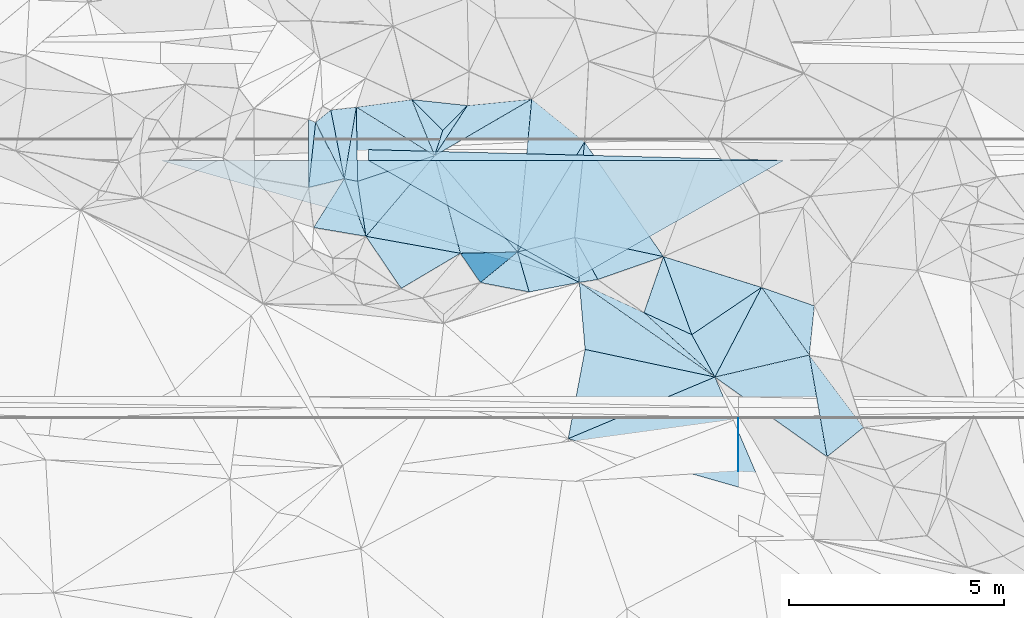
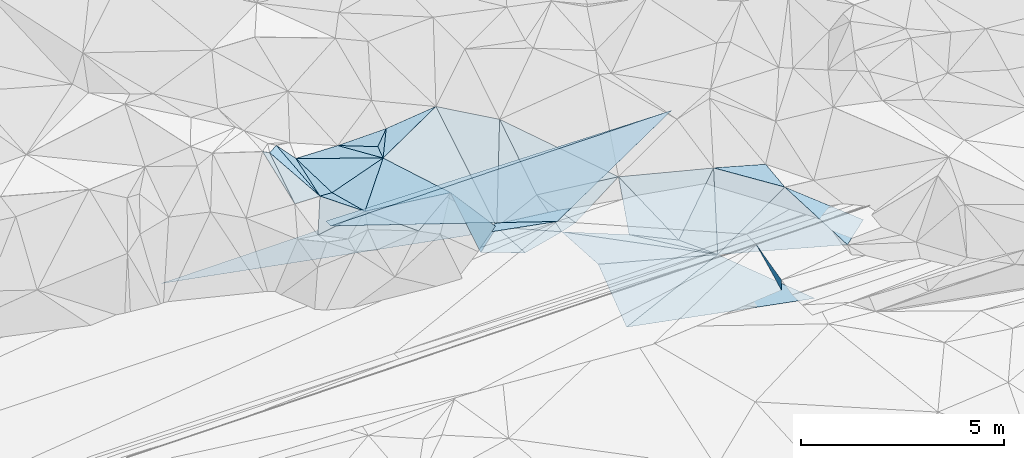
# One storey, part 49 of 275: 49 plates.
"""IFC2X3 building model written with IfcOpenShell, lengths in millimetres."""

from ifc_helpers import new_model, si_unit, frame, origin_with_axes, place, context, subcontext, project, spatial, polyline, outline, extrude, material, type_object, element, save


model = new_model("IFC2X3")

# Units and contexts
model_context = context("Model", 3, precision=1e-05, world=origin_with_axes())
body_context = subcontext(model_context, "Body", "Model", "MODEL_VIEW")
ifc_project = project(units=[si_unit("LENGTHUNIT", "METRE", prefix="MILLI"), si_unit("AREAUNIT", "SQUARE_METRE"), si_unit("VOLUMEUNIT", "CUBIC_METRE"), si_unit("MASSUNIT", "GRAM", prefix="KILO"), si_unit("TIMEUNIT", "SECOND"), si_unit("PLANEANGLEUNIT", "RADIAN"), si_unit("SOLIDANGLEUNIT", "STERADIAN"), si_unit("THERMODYNAMICTEMPERATUREUNIT", "DEGREE_CELSIUS"), si_unit("LUMINOUSINTENSITYUNIT", "LUMEN")], contexts=[model_context])

# Site, building, storey
site_placement = place(None, origin_with_axes())
site = spatial("IfcSite", under=ifc_project, at=site_placement, CompositionType="ELEMENT")
building_placement = place(site_placement, origin_with_axes())
building = spatial("IfcBuilding", under=site, at=building_placement, Name="Undefined", CompositionType="ELEMENT")
storey_placement = place(building_placement, origin_with_axes())
storey = spatial("IfcBuildingStorey", under=building, at=storey_placement, Name="Undefined", CompositionType="ELEMENT", Elevation=0.0)

# Plates
ifc_material = material()
plate_type_1 = type_object("IfcPlateType", PredefinedType="NOTDEFINED")
for number, where, z_axis, x_axis, name in (
    (1, (-129444.521961676, 66044.2965018914, 48899.9311651703), (0.00832149793297365, -0.0249918019511436, -0.9996530210565), (0.999965340787191, -5.73519775278889e-05, 0.0083254990906575), "00_PR"),
    (2, (-129444.521961676, 66044.2965018914, 48899.9311651703), (0.00832149793297365, -0.0249918019511436, -0.9996530210565), (0.999965340787191, -5.73519775278889e-05, 0.0083254990906575), "00_PR"),
    (3, (-129444.521961676, 66044.2965018914, 48899.9311651703), (0.00832149793297365, -0.0249918019511436, -0.9996530210565), (0.999965340787191, -5.73519775278889e-05, 0.0083254990906575), "00_PR"),
):
    element("IfcPlate", number, at=place(storey_placement, frame(where, z_axis=z_axis, x_axis=x_axis)), inside=storey, type_object=plate_type_1, material=ifc_material, Name=name, context=body_context, shape_type="SweptSolid", body=[
        extrude(outline(polyline([(0.0, 0.0), (9668.6904296875, -3.96539689972997e-09), (4834.9169921875, 2750.859375), (0.0, 0.0)])), frame((-8.85201319254618e-08, 2.18876761149539e-07, -0.5000001331573), z_axis=(0.0, 0.0, 1.0), x_axis=(1.0, 0.0, 0.0)), (0.0, 0.0, 1.0), 1.0),
    ])
plate_type_2 = type_object("IfcPlateType", PredefinedType="NOTDEFINED")
for number, where, z_axis, x_axis, name in (
    (4, (-129444.521961676, 66044.2965018914, 48899.9311651703), (0.00832149793297365, -0.0249918019511436, -0.9996530210565), (5.72779774420735e-05, 0.999687644773175, -0.0249921909222736), "00_PR"),
    (5, (-129444.521961676, 66044.2965018914, 48899.9311651703), (0.00832149793297365, -0.0249918019511436, -0.9996530210565), (5.72779774420735e-05, 0.999687644773175, -0.0249921909222736), "00_PR"),
    (6, (-129444.521961676, 66044.2965018914, 48899.9311651703), (0.00832149793297365, -0.0249918019511436, -0.9996530210565), (5.72779774420735e-05, 0.999687644773175, -0.0249921909222736), "00_PR"),
):
    element("IfcPlate", number, at=place(storey_placement, frame(where, z_axis=z_axis, x_axis=x_axis)), inside=storey, type_object=plate_type_2, material=ifc_material, Name=name, context=body_context, shape_type="SweptSolid", body=[
        extrude(outline(polyline([(0.0, 0.0), (250.078109741211, 1.02591002359986e-09), (-2.01160454750061, 9668.6904296875), (0.0, 0.0)])), frame((-8.85201319254618e-08, 2.18876761149539e-07, -0.5000001331573), z_axis=(0.0, 0.0, 1.0), x_axis=(1.0, 0.0, 0.0)), (0.0, 0.0, 1.0), 1.0),
    ])
plate_type_3 = type_object("IfcPlateType", PredefinedType="NOTDEFINED")
plate_1_placement = place(storey_placement, frame((-130003.227472833, 65617.2037920158, 50249.5041689659), z_axis=(0.0757378480211885, -0.104639151422614, -0.991622118736101), x_axis=(0.977749258374854, -0.187314348891937, 0.0944442822335632)))
element("IfcPlate", 7, at=plate_1_placement, inside=storey, type_object=plate_type_3, material=ifc_material, Name="00", context=body_context, shape_type="SweptSolid", body=[
    extrude(outline(polyline([(0.0, 0.0), (317.647613525391, 1.92812876775861e-09), (761.850524902344, 1226.08471679688), (0.0, 0.0)])), frame((-8.85201319254618e-08, 2.18876761149539e-07, -0.5000001331573), z_axis=(0.0, 0.0, 1.0), x_axis=(1.0, 0.0, 0.0)), (0.0, 0.0, 1.0), 1.0),
])
plate_type_4 = type_object("IfcPlateType", PredefinedType="NOTDEFINED")
plate_2_placement = place(storey_placement, frame((-127137.605546516, 67321.4208764742, 50239.5053374167), z_axis=(0.0950803082554427, -0.110798728565862, -0.989284274983808), x_axis=(-0.702212597919709, -0.711862135152669, 0.0122379679169896)))
element("IfcPlate", 8, at=plate_2_placement, inside=storey, type_object=plate_type_4, material=ifc_material, Name="00", context=body_context, shape_type="SweptSolid", body=[
    extrude(outline(polyline([(0.0, 0.0), (817.129150390625, -2.46654963120818e-09), (810.643005371094, 1030.46496582031), (0.0, 0.0)])), frame((-8.85201319254618e-08, 2.18876761149539e-07, -0.5000001331573), z_axis=(0.0, 0.0, 1.0), x_axis=(1.0, 0.0, 0.0)), (0.0, 0.0, 1.0), 1.0),
])
plate_type_5 = type_object("IfcPlateType", PredefinedType="NOTDEFINED")
plate_3_placement = place(storey_placement, frame((-119179.632955102, 61513.3747925366, 49219.5090029932), z_axis=(-0.0880734483260921, 0.167321221963966, -0.981960628732352), x_axis=(0.587966270137878, -0.787011487859707, -0.186838387803474)))
element("IfcPlate", 9, at=plate_3_placement, inside=storey, type_object=plate_type_5, material=ifc_material, Name="00", context=body_context, shape_type="SweptSolid", body=[
    extrude(outline(polyline([(0.0, 0.0), (2140.8876953125, -8.41828295961022e-09), (2185.96240234375, 1086.49353027344), (0.0, 0.0)])), frame((-8.85201319254618e-08, 2.18876761149539e-07, -0.5000001331573), z_axis=(0.0, 0.0, 1.0), x_axis=(1.0, 0.0, 0.0)), (0.0, 0.0, 1.0), 1.0),
])
plate_type_6 = type_object("IfcPlateType", PredefinedType="NOTDEFINED")
plate_4_placement = place(storey_placement, frame((-125969.525330926, 63912.8597103929, 48939.5338192046), z_axis=(0.124923611641997, 0.339308757605483, -0.932343101152437), x_axis=(0.486195842697802, 0.798207706932544, 0.355637538987189)))
element("IfcPlate", 10, at=plate_4_placement, inside=storey, type_object=plate_type_6, material=ifc_material, Name="00", context=body_context, shape_type="SweptSolid", body=[
    extrude(outline(polyline([(0.0, 0.0), (3205.51098632813, 6.40284270048141e-09), (1020.02459716797, 961.743103027344), (0.0, 0.0)])), frame((-8.85201319254618e-08, 2.18876761149539e-07, -0.5000001331573), z_axis=(0.0, 0.0, 1.0), x_axis=(1.0, 0.0, 0.0)), (0.0, 0.0, 1.0), 1.0),
])
plate_type_7 = type_object("IfcPlateType", PredefinedType="NOTDEFINED")
plate_5_placement = place(storey_placement, frame((-120291.181343538, 63088.3693610962, 49229.5448180347), z_axis=(0.335384816319633, 0.242527733238209, -0.910328140613363), x_axis=(0.576684367356679, -0.816950570194428, -0.00518712882303245)))
element("IfcPlate", 11, at=plate_5_placement, inside=storey, type_object=plate_type_7, material=ifc_material, Name="00", context=body_context, shape_type="SweptSolid", body=[
    extrude(outline(polyline([(0.0, 0.0), (1927.84851074219, -3.20869730785489e-09), (1083.02600097656, 2296.41479492188), (0.0, 0.0)])), frame((-8.85201319254618e-08, 2.18876761149539e-07, -0.5000001331573), z_axis=(0.0, 0.0, 1.0), x_axis=(1.0, 0.0, 0.0)), (0.0, 0.0, 1.0), 1.0),
])
plate_type_8 = type_object("IfcPlateType", PredefinedType="NOTDEFINED")
plate_6_placement = place(storey_placement, frame((-129498.191015569, 64276.9670685408, 50429.5038337111), z_axis=(0.0631159994664881, -0.106634195896618, -0.992293060983915), x_axis=(-0.149120046090259, 0.982106199594028, -0.115024452065697)))
element("IfcPlate", 12, at=plate_6_placement, inside=storey, type_object=plate_type_8, material=ifc_material, Name="00", context=body_context, shape_type="SweptSolid", body=[
    extrude(outline(polyline([(0.0, 0.0), (1304.07055664063, -5.67524693906307e-10), (1615.94018554688, 1863.34033203125), (0.0, 0.0)])), frame((-8.85201319254618e-08, 2.18876761149539e-07, -0.5000001331573), z_axis=(0.0, 0.0, 1.0), x_axis=(1.0, 0.0, 0.0)), (0.0, 0.0, 1.0), 1.0),
])
plate_type_9 = type_object("IfcPlateType", PredefinedType="NOTDEFINED")
plate_7_placement = place(storey_placement, frame((-124532.389340275, 63204.5267932217, 48725.5550051156), z_axis=(0.0880257875821797, 0.447439800095917, -0.889971396175553), x_axis=(-0.889061882563132, 0.438226990051846, 0.132386079945739)))
element("IfcPlate", 13, at=plate_7_placement, inside=storey, type_object=plate_type_9, material=ifc_material, Name="00", context=body_context, shape_type="SweptSolid", body=[
    extrude(outline(polyline([(0.0, 0.0), (1616.48413085938, 8.94578988663852e-09), (622.802917480469, 988.937561035156), (0.0, 0.0)])), frame((-8.85201319254618e-08, 2.18876761149539e-07, -0.5000001331573), z_axis=(0.0, 0.0, 1.0), x_axis=(1.0, 0.0, 0.0)), (0.0, 0.0, 1.0), 1.0),
])
plate_type_10 = type_object("IfcPlateType", PredefinedType="NOTDEFINED")
plate_8_placement = place(storey_placement, frame((-124532.491158292, 63204.3223012122, 48725.5036896782), z_axis=(-0.115376126283496, 0.038431630829375, -0.992578137597041), x_axis=(0.814371086853017, -0.568495484194326, -0.116673121791162)))
element("IfcPlate", 14, at=plate_8_placement, inside=storey, type_object=plate_type_10, material=ifc_material, Name="00", context=body_context, shape_type="SweptSolid", body=[
    extrude(outline(polyline([(0.0, 0.0), (3874.0712890625, -4.55474946647882e-09), (1004.98455810547, 1202.99914550781), (0.0, 0.0)])), frame((-8.85201319254618e-08, 2.18876761149539e-07, -0.5000001331573), z_axis=(0.0, 0.0, 1.0), x_axis=(1.0, 0.0, 0.0)), (0.0, 0.0, 1.0), 1.0),
])
plate_type_11 = type_object("IfcPlateType", PredefinedType="NOTDEFINED")
plate_9_placement = place(storey_placement, frame((-125969.952740655, 63912.5752890697, 48939.6780395793), z_axis=(-0.729883354677773, -0.229538386835784, -0.643880747913111), x_axis=(-0.658758887831383, -0.0152879310351082, 0.752198781485204)))
element("IfcPlate", 15, at=plate_9_placement, inside=storey, type_object=plate_type_11, material=ifc_material, Name="00", context=body_context, shape_type="SweptSolid", body=[
    extrude(outline(polyline([(0.0, 0.0), (2020.74243164063, -2.76850187219679e-09), (2283.26977539063, 2338.22143554688), (0.0, 0.0)])), frame((-8.85201319254618e-08, 2.18876761149539e-07, -0.5000001331573), z_axis=(0.0, 0.0, 1.0), x_axis=(1.0, 0.0, 0.0)), (0.0, 0.0, 1.0), 1.0),
])
plate_type_12 = type_object("IfcPlateType", PredefinedType="NOTDEFINED")
plate_10_placement = place(storey_placement, frame((-127900.420554066, 66153.240336265, 50329.5032199923), z_axis=(0.0435603591304692, -0.104987015603955, -0.993519109865029), x_axis=(0.545601572733032, 0.835568580895548, -0.064374454960352)))
element("IfcPlate", 16, at=plate_10_placement, inside=storey, type_object=plate_type_12, material=ifc_material, Name="00", context=body_context, shape_type="SweptSolid", body=[
    extrude(outline(polyline([(0.0, 0.0), (1398.07006835938, 4.16184775531292e-09), (2336.07739257813, 1178.32177734375), (0.0, 0.0)])), frame((-8.85201319254618e-08, 2.18876761149539e-07, -0.5000001331573), z_axis=(0.0, 0.0, 1.0), x_axis=(1.0, 0.0, 0.0)), (0.0, 0.0, 1.0), 1.0),
])
plate_type_13 = type_object("IfcPlateType", PredefinedType="NOTDEFINED")
for number, where, z_axis, x_axis, name in (
    (17, (-120831.12012362, 60043.8155718842, 48953.4049923113), (-0.999999998319634, 5.7971816915469e-05, -5.18701054120542e-10), (-5.18509337020751e-05, -0.894420226089169, -0.447227522044518), "00_PR"),
    (18, (-120831.12012362, 60043.8155718842, 48953.4049923113), (-0.999999998319634, 5.7971816915469e-05, -5.18701054120542e-10), (-5.18509337020751e-05, -0.894420226089169, -0.447227522044518), "00_PR"),
    (19, (-120831.12012362, 60043.8155718842, 48953.4049923113), (-0.999999998319634, 5.7971816915469e-05, -5.18701054120542e-10), (-5.18509337020751e-05, -0.894420226089169, -0.447227522044518), "00_PR"),
):
    element("IfcPlate", number, at=place(storey_placement, frame(where, z_axis=z_axis, x_axis=x_axis)), inside=storey, type_object=plate_type_13, material=ifc_material, Name=name, context=body_context, shape_type="SweptSolid", body=[
        extrude(outline(polyline([(0.0, 0.0), (1373.74145507813, -2.00088834390044e-09), (1236.35314941406, 274.765899658203), (0.0, 0.0)])), frame((-8.85201319254618e-08, 2.18876761149539e-07, -0.5000001331573), z_axis=(0.0, 0.0, 1.0), x_axis=(1.0, 0.0, 0.0)), (0.0, 0.0, 1.0), 1.0),
    ])
plate_type_14 = type_object("IfcPlateType", PredefinedType="NOTDEFINED")
plate_11_placement = place(storey_placement, frame((-134278.700031969, 66044.5731858637, 48859.6831648337), z_axis=(0.00832149793297365, -0.0249918019511436, -0.9996530210565), x_axis=(0.999965340787191, -5.73519775278889e-05, 0.0083254990906575)))
element("IfcPlate", 20, at=plate_11_placement, inside=storey, type_object=plate_type_14, material=ifc_material, Name="00_PR", context=body_context, shape_type="SweptSolid", body=[
    extrude(outline(polyline([(0.0, 0.0), (4834.345703125, 2.56695784628391e-08), (9669.2626953125, 2750.85961914063), (0.0, 0.0)])), frame((-8.85201319254618e-08, 2.18876761149539e-07, -0.5000001331573), z_axis=(0.0, 0.0, 1.0), x_axis=(1.0, 0.0, 0.0)), (0.0, 0.0, 1.0), 1.0),
])
plate_type_15 = type_object("IfcPlateType", PredefinedType="NOTDEFINED")
plate_12_placement = place(storey_placement, frame((-127900.355573327, 66153.1989350294, 50329.5166081926), z_axis=(0.173512563902205, -0.187780643580185, -0.966763580232879), x_axis=(0.304152191876711, 0.943883164155525, -0.128747879983894)))
element("IfcPlate", 21, at=plate_12_placement, inside=storey, type_object=plate_type_15, material=ifc_material, Name="00", context=body_context, shape_type="SweptSolid", body=[
    extrude(outline(polyline([(0.0, 0.0), (621.369445800781, -1.00408215075731e-09), (1346.21997070313, 377.215667724609), (0.0, 0.0)])), frame((-8.85201319254618e-08, 2.18876761149539e-07, -0.5000001331573), z_axis=(0.0, 0.0, 1.0), x_axis=(1.0, 0.0, 0.0)), (0.0, 0.0, 1.0), 1.0),
])
plate_type_16 = type_object("IfcPlateType", PredefinedType="NOTDEFINED")
plate_13_placement = place(storey_placement, frame((-118767.770760546, 59147.8515516211, 48779.543804429), z_axis=(0.339464407707065, 0.228776955956658, -0.912373290009795), x_axis=(-0.805182138904596, 0.572106788671328, -0.156126697093097)))
element("IfcPlate", 22, at=plate_13_placement, inside=storey, type_object=plate_type_16, material=ifc_material, Name="00", context=body_context, shape_type="SweptSolid", body=[
    extrude(outline(polyline([(0.0, 0.0), (3240.95751953125, 3.48518369719386e-09), (1616.10571289063, 1829.5087890625), (0.0, 0.0)])), frame((-8.85201319254618e-08, 2.18876761149539e-07, -0.5000001331573), z_axis=(0.0, 0.0, 1.0), x_axis=(1.0, 0.0, 0.0)), (0.0, 0.0, 1.0), 1.0),
])
plate_type_17 = type_object("IfcPlateType", PredefinedType="NOTDEFINED")
plate_14_placement = place(storey_placement, frame((-130833.201857726, 66999.936863325, 51039.5373438327), z_axis=(-0.130654872348057, 0.356037051392011, -0.925292884641288), x_axis=(0.882890951907002, -0.382804218746595, -0.271964146810856)))
element("IfcPlate", 23, at=plate_14_placement, inside=storey, type_object=plate_type_17, material=ifc_material, Name="00", context=body_context, shape_type="SweptSolid", body=[
    extrude(outline(polyline([(0.0, 0.0), (183.847763061523, -6.73026079311967e-11), (773.466003417969, 1511.93591308594), (0.0, 0.0)])), frame((-8.85201319254618e-08, 2.18876761149539e-07, -0.5000001331573), z_axis=(0.0, 0.0, 1.0), x_axis=(1.0, 0.0, 0.0)), (0.0, 0.0, 1.0), 1.0),
])
plate_type_18 = type_object("IfcPlateType", PredefinedType="NOTDEFINED")
plate_15_placement = place(storey_placement, frame((-123027.890166887, 62501.7149343319, 48539.5035118259), z_axis=(-0.0833286643851927, 0.0844140371860381, -0.992940382912154), x_axis=(0.734854249091611, -0.667802817843535, -0.118442513787233)))
element("IfcPlate", 24, at=plate_15_placement, inside=storey, type_object=plate_type_18, material=ifc_material, Name="00", context=body_context, shape_type="SweptSolid", body=[
    extrude(outline(polyline([(0.0, 0.0), (2245.81518554688, 1.41371856443584e-08), (-1596.8994140625, 491.907775878906), (0.0, 0.0)])), frame((-8.85201319254618e-08, 2.18876761149539e-07, -0.5000001331573), z_axis=(0.0, 0.0, 1.0), x_axis=(1.0, 0.0, 0.0)), (0.0, 0.0, 1.0), 1.0),
])
plate_type_19 = type_object("IfcPlateType", PredefinedType="NOTDEFINED")
plate_16_placement = place(storey_placement, frame((-125700.405192181, 62982.2301880415, 48639.5246906612), z_axis=(-0.17663050175938, 0.255336486957941, -0.950581371727958), x_axis=(-0.95612964042597, 0.184798877921417, 0.227300429867369)))
element("IfcPlate", 25, at=plate_16_placement, inside=storey, type_object=plate_type_19, material=ifc_material, Name="00", context=body_context, shape_type="SweptSolid", body=[
    extrude(outline(polyline([(0.0, 0.0), (1187.85522460938, 4.16184775531292e-09), (497.619567871094, 883.671203613281), (0.0, 0.0)])), frame((-8.85201319254618e-08, 2.18876761149539e-07, -0.5000001331573), z_axis=(0.0, 0.0, 1.0), x_axis=(1.0, 0.0, 0.0)), (0.0, 0.0, 1.0), 1.0),
])
plate_type_20 = type_object("IfcPlateType", PredefinedType="NOTDEFINED")
plate_17_placement = place(storey_placement, frame((-128433.955680999, 67458.9867109266, 50099.5065116747), z_axis=(0.0536642280951734, -0.151912877551739, -0.986935979816776), x_axis=(0.70115609517819, -0.697991184940187, 0.145562481224614)))
element("IfcPlate", 26, at=plate_17_placement, inside=storey, type_object=plate_type_20, material=ifc_material, Name="00", context=body_context, shape_type="SweptSolid", body=[
    extrude(outline(polyline([(0.0, 0.0), (1030.4853515625, -7.60337570682168e-09), (1318.99011230469, 550.331665039063), (0.0, 0.0)])), frame((-8.85201319254618e-08, 2.18876761149539e-07, -0.5000001331573), z_axis=(0.0, 0.0, 1.0), x_axis=(1.0, 0.0, 0.0)), (0.0, 0.0, 1.0), 1.0),
])
plate_type_21 = type_object("IfcPlateType", PredefinedType="NOTDEFINED")
plate_18_placement = place(storey_placement, frame((-121377.318631413, 61002.0226931431, 48273.5482855984), z_axis=(0.366026678694528, 0.223397463153272, -0.90339251930738), x_axis=(-0.47857781403254, 0.877739938706717, 0.0231489938218709)))
element("IfcPlate", 27, at=plate_18_placement, inside=storey, type_object=plate_type_21, material=ifc_material, Name="00", context=body_context, shape_type="SweptSolid", body=[
    extrude(outline(polyline([(0.0, 0.0), (1123.15893554688, -1.60071067512035e-10), (1333.58325195313, 2160.560546875), (0.0, 0.0)])), frame((-8.85201319254618e-08, 2.18876761149539e-07, -0.5000001331573), z_axis=(0.0, 0.0, 1.0), x_axis=(1.0, 0.0, 0.0)), (0.0, 0.0, 1.0), 1.0),
])
plate_type_22 = type_object("IfcPlateType", PredefinedType="NOTDEFINED")
plate_19_placement = place(storey_placement, frame((-129722.757470275, 67282.8896981557, 50269.5022630749), z_axis=(0.0953660419726231, -0.00410516051515797, -0.995433807792171), x_axis=(0.0174562651765751, -0.999830830226952, 0.00579566508434712)))
element("IfcPlate", 28, at=plate_19_placement, inside=storey, type_object=plate_type_22, material=ifc_material, Name="00", context=body_context, shape_type="SweptSolid", body=[
    extrude(outline(polyline([(0.0, 0.0), (1725.42749023438, -1.01426849141717e-08), (1660.34216308594, 310.908172607422), (0.0, 0.0)])), frame((-8.85201319254618e-08, 2.18876761149539e-07, -0.5000001331573), z_axis=(0.0, 0.0, 1.0), x_axis=(1.0, 0.0, 0.0)), (0.0, 0.0, 1.0), 1.0),
])
plate_type_23 = type_object("IfcPlateType", PredefinedType="NOTDEFINED")
plate_20_placement = place(storey_placement, frame((-122576.436154404, 63805.74018501, 49329.5620183734), z_axis=(0.137299005952547, 0.462493282403943, -0.875927477988714), x_axis=(-0.898756926581434, -0.31357221407103, -0.306444862062471)))
element("IfcPlate", 29, at=plate_20_placement, inside=storey, type_object=plate_type_23, material=ifc_material, Name="00", context=body_context, shape_type="SweptSolid", body=[
    extrude(outline(polyline([(0.0, 0.0), (1696.87951660156, 6.92671164870262e-09), (1745.02673339844, 1193.60034179688), (0.0, 0.0)])), frame((-8.85201319254618e-08, 2.18876761149539e-07, -0.5000001331573), z_axis=(0.0, 0.0, 1.0), x_axis=(1.0, 0.0, 0.0)), (0.0, 0.0, 1.0), 1.0),
])
plate_type_24 = type_object("IfcPlateType", PredefinedType="NOTDEFINED")
plate_21_placement = place(storey_placement, frame((-127900.491971732, 66153.1869172242, 50329.5138542138), z_axis=(-0.0992887871817389, -0.211823215377157, -0.972251336932618), x_axis=(-0.849625641007612, 0.526643867806528, -0.0279733202209757)))
element("IfcPlate", 30, at=plate_21_placement, inside=storey, type_object=plate_type_24, material=ifc_material, Name="00", context=body_context, shape_type="SweptSolid", body=[
    extrude(outline(polyline([(0.0, 0.0), (2144.90087890625, 3.61978891305625e-09), (1147.4189453125, 852.073791503906), (0.0, 0.0)])), frame((-8.85201319254618e-08, 2.18876761149539e-07, -0.5000001331573), z_axis=(0.0, 0.0, 1.0), x_axis=(1.0, 0.0, 0.0)), (0.0, 0.0, 1.0), 1.0),
])
plate_type_25 = type_object("IfcPlateType", PredefinedType="NOTDEFINED")
plate_22_placement = place(storey_placement, frame((-127900.427509511, 66153.2901867918, 50329.5002167585), z_axis=(0.0296386749908804, -0.00527655011624774, -0.999546750764393), x_axis=(-0.948648755546511, -0.315222336048504, -0.026465401115051)))
element("IfcPlate", 31, at=plate_22_placement, inside=storey, type_object=plate_type_25, material=ifc_material, Name="00", context=body_context, shape_type="SweptSolid", body=[
    extrude(outline(polyline([(0.0, 0.0), (1889.25915527344, 5.03496266901493e-09), (1374.29528808594, 1646.78845214844), (0.0, 0.0)])), frame((-8.85201319254618e-08, 2.18876761149539e-07, -0.5000001331573), z_axis=(0.0, 0.0, 1.0), x_axis=(1.0, 0.0, 0.0)), (0.0, 0.0, 1.0), 1.0),
])
plate_type_26 = type_object("IfcPlateType", PredefinedType="NOTDEFINED")
plate_23_placement = place(storey_placement, frame((-127900.440570346, 66153.2647246078, 50329.5007740433), z_axis=(0.0035207137712639, -0.0562107062753068, -0.998412720809672), x_axis=(0.254863852238871, -0.965397214298352, 0.0552506601494059)))
element("IfcPlate", 32, at=plate_23_placement, inside=storey, type_object=plate_type_26, material=ifc_material, Name="00", context=body_context, shape_type="SweptSolid", body=[
    extrude(outline(polyline([(0.0, 0.0), (2352.9130859375, -5.0495145842433e-09), (1409.65686035156, 2023.89916992188), (0.0, 0.0)])), frame((-8.85201319254618e-08, 2.18876761149539e-07, -0.5000001331573), z_axis=(0.0, 0.0, 1.0), x_axis=(1.0, 0.0, 0.0)), (0.0, 0.0, 1.0), 1.0),
])
plate_type_27 = type_object("IfcPlateType", PredefinedType="NOTDEFINED")
plate_24_placement = place(storey_placement, frame((-125639.663784851, 67469.993557538, 50289.5340466144), z_axis=(0.119154795137564, 0.342619530449373, -0.931887328034015), x_axis=(0.769314728427302, -0.625191810052689, -0.131491631930966)))
element("IfcPlate", 33, at=plate_24_placement, inside=storey, type_object=plate_type_27, material=ifc_material, Name="00", context=body_context, shape_type="SweptSolid", body=[
    extrude(outline(polyline([(0.0, 0.0), (1597.05981445313, -2.94676283374429e-10), (2147.63403320313, 3157.8740234375), (0.0, 0.0)])), frame((-8.85201319254618e-08, 2.18876761149539e-07, -0.5000001331573), z_axis=(0.0, 0.0, 1.0), x_axis=(1.0, 0.0, 0.0)), (0.0, 0.0, 1.0), 1.0),
])
plate_type_28 = type_object("IfcPlateType", PredefinedType="NOTDEFINED")
plate_25_placement = place(storey_placement, frame((-120291.37990113, 63088.2294712512, 49229.5012922297), z_axis=(-0.0617333005592953, -0.0372446025443736, -0.997397533174896), x_axis=(0.942901871509231, -0.329872958992702, -0.0460422808925567)))
element("IfcPlate", 34, at=plate_25_placement, inside=storey, type_object=plate_type_28, material=ifc_material, Name="00", context=body_context, shape_type="SweptSolid", body=[
    extrude(outline(polyline([(0.0, 0.0), (1303.15002441406, -8.92032403498888e-09), (1568.27685546875, 1121.20812988281), (0.0, 0.0)])), frame((-8.85201319254618e-08, 2.18876761149539e-07, -0.5000001331573), z_axis=(0.0, 0.0, 1.0), x_axis=(1.0, 0.0, 0.0)), (0.0, 0.0, 1.0), 1.0),
])
plate_type_29 = type_object("IfcPlateType", PredefinedType="NOTDEFINED")
plate_26_placement = place(storey_placement, frame((-130671.02851625, 66929.5185759375, 50989.5673045566), z_axis=(-0.419029101582862, 0.274859535489317, -0.8653709307443), x_axis=(0.764320372065501, 0.621259706272903, -0.172773684938885)))
element("IfcPlate", 35, at=plate_26_placement, inside=storey, type_object=plate_type_29, material=ifc_material, Name="00", context=body_context, shape_type="SweptSolid", body=[
    extrude(outline(polyline([(0.0, 0.0), (463.033477783203, 3.20142135024071e-09), (-177.093032836914, 1638.15075683594), (0.0, 0.0)])), frame((-8.85201319254618e-08, 2.18876761149539e-07, -0.5000001331573), z_axis=(0.0, 0.0, 1.0), x_axis=(1.0, 0.0, 0.0)), (0.0, 0.0, 1.0), 1.0),
])
plate_27_placement = place(storey_placement, frame((-124101.536338507, 63273.6386784297, 48809.5558439795), z_axis=(0.10131968316145, 0.44799805754835, -0.888274767308499), x_axis=(-0.969575789878977, -0.155528612165952, -0.189033432170849)))
element("IfcPlate", 36, at=plate_27_placement, inside=storey, type_object=plate_type_29, material=ifc_material, Name="00", context=body_context, shape_type="SweptSolid", body=[
    extrude(outline(polyline([(0.0, 0.0), (444.365844726563, 2.3283064365387e-09), (290.953948974609, 1158.59643554688), (0.0, 0.0)])), frame((-8.85201319254618e-08, 2.18876761149539e-07, -0.5000001331573), z_axis=(0.0, 0.0, 1.0), x_axis=(1.0, 0.0, 0.0)), (0.0, 0.0, 1.0), 1.0),
])
plate_type_30 = type_object("IfcPlateType", PredefinedType="NOTDEFINED")
plate_28_placement = place(storey_placement, frame((-130003.106290604, 65617.2523892245, 50249.5259692242), z_axis=(0.318125596382848, -0.00744380338211473, -0.948019353556279), x_axis=(0.349873107044103, -0.928460847684472, 0.124696685137728)))
element("IfcPlate", 37, at=plate_28_placement, inside=storey, type_object=plate_type_30, material=ifc_material, Name="00", context=body_context, shape_type="SweptSolid", body=[
    extrude(outline(polyline([(0.0, 0.0), (1443.50268554688, 2.25554686039686e-09), (775.821228027344, 1116.06518554688), (0.0, 0.0)])), frame((-8.85201319254618e-08, 2.18876761149539e-07, -0.5000001331573), z_axis=(0.0, 0.0, 1.0), x_axis=(1.0, 0.0, 0.0)), (0.0, 0.0, 1.0), 1.0),
])
plate_type_31 = type_object("IfcPlateType", PredefinedType="NOTDEFINED")
plate_29_placement = place(storey_placement, frame((-128678.150550806, 63065.1856757273, 50289.5053225869), z_axis=(0.0387810562282924, 0.140528235178958, -0.989316857632228), x_axis=(-0.557871846985221, 0.824444229663337, 0.0952402988032128)))
element("IfcPlate", 38, at=plate_29_placement, inside=storey, type_object=plate_type_31, material=ifc_material, Name="00", context=body_context, shape_type="SweptSolid", body=[
    extrude(outline(polyline([(0.0, 0.0), (1469.96594238281, -6.33008312433958e-09), (-78.9133911132813, 1608.37573242188), (0.0, 0.0)])), frame((-8.85201319254618e-08, 2.18876761149539e-07, -0.5000001331573), z_axis=(0.0, 0.0, 1.0), x_axis=(1.0, 0.0, 0.0)), (0.0, 0.0, 1.0), 1.0),
])
plate_type_32 = type_object("IfcPlateType", PredefinedType="NOTDEFINED")
plate_30_placement = place(storey_placement, frame((-121914.996772259, 61988.005200947, 48299.5692271149), z_axis=(0.0476476560456979, 0.505498988839844, -0.861510576345552), x_axis=(-0.890946835944221, 0.411452336777698, 0.192147625749457)))
element("IfcPlate", 39, at=plate_30_placement, inside=storey, type_object=plate_type_32, material=ifc_material, Name="00", context=body_context, shape_type="SweptSolid", body=[
    extrude(outline(polyline([(0.0, 0.0), (1249.03967285156, 6.27187546342611e-09), (1535.17944335938, 1563.94506835938), (0.0, 0.0)])), frame((-8.85201319254618e-08, 2.18876761149539e-07, -0.5000001331573), z_axis=(0.0, 0.0, 1.0), x_axis=(1.0, 0.0, 0.0)), (0.0, 0.0, 1.0), 1.0),
])
plate_type_33 = type_object("IfcPlateType", PredefinedType="NOTDEFINED")
plate_31_placement = place(storey_placement, frame((-121377.631966233, 61001.8525763853, 48273.5208122388), z_axis=(-0.260638629396983, -0.116835564353439, -0.958340730517218), x_axis=(-0.734854249096195, 0.667802817837573, 0.118442513792408)))
element("IfcPlate", 40, at=plate_31_placement, inside=storey, type_object=plate_type_33, material=ifc_material, Name="00", context=body_context, shape_type="SweptSolid", body=[
    extrude(outline(polyline([(0.0, 0.0), (2245.81518554688, 1.41371856443584e-08), (1056.42529296875, 381.381164550781), (0.0, 0.0)])), frame((-8.85201319254618e-08, 2.18876761149539e-07, -0.5000001331573), z_axis=(0.0, 0.0, 1.0), x_axis=(1.0, 0.0, 0.0)), (0.0, 0.0, 1.0), 1.0),
])
plate_type_34 = type_object("IfcPlateType", PredefinedType="NOTDEFINED")
plate_32_placement = place(storey_placement, frame((-127301.045221766, 63882.1425373805, 50459.7658253393), z_axis=(-0.550770857280458, 0.690895381614182, -0.468310831003025), x_axis=(0.65875888782618, 0.0152879310404223, -0.752198781489652)))
element("IfcPlate", 41, at=plate_32_placement, inside=storey, type_object=plate_type_34, material=ifc_material, Name="00", context=body_context, shape_type="SweptSolid", body=[
    extrude(outline(polyline([(0.0, 0.0), (2020.74243164063, -2.76850187219679e-09), (1461.64099121094, 971.959655761719), (0.0, 0.0)])), frame((-8.85201319254618e-08, 2.18876761149539e-07, -0.5000001331573), z_axis=(0.0, 0.0, 1.0), x_axis=(1.0, 0.0, 0.0)), (0.0, 0.0, 1.0), 1.0),
])
plate_type_35 = type_object("IfcPlateType", PredefinedType="NOTDEFINED")
plate_33_placement = place(storey_placement, frame((-125969.701743144, 63912.8720044807, 48939.548414082), z_axis=(-0.227890633047121, 0.3638895769183, -0.903133564418687), x_axis=(-0.59081529635985, 0.685594055112089, 0.425321145938201)))
element("IfcPlate", 42, at=plate_33_placement, inside=storey, type_object=plate_type_35, material=ifc_material, Name="00", context=body_context, shape_type="SweptSolid", body=[
    extrude(outline(polyline([(0.0, 0.0), (3268.11865234375, -1.8168066162616e-08), (2818.04321289063, 2577.42749023438), (0.0, 0.0)])), frame((-8.85201319254618e-08, 2.18876761149539e-07, -0.5000001331573), z_axis=(0.0, 0.0, 1.0), x_axis=(1.0, 0.0, 0.0)), (0.0, 0.0, 1.0), 1.0),
])
plate_type_36 = type_object("IfcPlateType", PredefinedType="NOTDEFINED")
plate_34_placement = place(storey_placement, frame((-125969.582254106, 63912.8449163165, 48939.5245981537), z_axis=(0.0110862761004422, 0.309712794935672, -0.950765522689669), x_axis=(0.889061882562011, -0.438226990080443, -0.132386079858602)))
element("IfcPlate", 43, at=plate_34_placement, inside=storey, type_object=plate_type_36, material=ifc_material, Name="00", context=body_context, shape_type="SweptSolid", body=[
    extrude(outline(polyline([(0.0, 0.0), (1616.48413085938, 8.94578988663852e-09), (686.922912597656, 746.0810546875), (0.0, 0.0)])), frame((-8.85201319254618e-08, 2.18876761149539e-07, -0.5000001331573), z_axis=(0.0, 0.0, 1.0), x_axis=(1.0, 0.0, 0.0)), (0.0, 0.0, 1.0), 1.0),
])
plate_type_37 = type_object("IfcPlateType", PredefinedType="NOTDEFINED")
plate_35_placement = place(storey_placement, frame((-130003.631963022, 65617.3218491773, 50249.666411487), z_axis=(-0.733241549240393, 0.131474010319668, -0.667136728922949), x_axis=(-0.17833276421858, 0.909602628983842, 0.375260552885382)))
element("IfcPlate", 44, at=plate_35_placement, inside=storey, type_object=plate_type_37, material=ifc_material, Name="00", context=body_context, shape_type="SweptSolid", body=[
    extrude(outline(polyline([(0.0, 0.0), (1758.77795410156, 5.51517587155104e-09), (1472.55651855469, 827.633544921875), (0.0, 0.0)])), frame((-8.85201319254618e-08, 2.18876761149539e-07, -0.5000001331573), z_axis=(0.0, 0.0, 1.0), x_axis=(1.0, 0.0, 0.0)), (0.0, 0.0, 1.0), 1.0),
])
plate_type_38 = type_object("IfcPlateType", PredefinedType="NOTDEFINED")
plate_36_placement = place(storey_placement, frame((-130003.405826094, 65617.4356206287, 50249.5549598544), z_axis=(-0.280958526838109, 0.359016154843801, -0.890039160238544), x_axis=(-0.950525611223216, -0.232158377195027, 0.20640627487289)))
element("IfcPlate", 45, at=plate_36_placement, inside=storey, type_object=plate_type_38, material=ifc_material, Name="00", context=body_context, shape_type="SweptSolid", body=[
    extrude(outline(polyline([(0.0, 0.0), (872.066528320313, -8.87666828930378e-10), (482.646667480469, 1575.42126464844), (0.0, 0.0)])), frame((-8.85201319254618e-08, 2.18876761149539e-07, -0.5000001331573), z_axis=(0.0, 0.0, 1.0), x_axis=(1.0, 0.0, 0.0)), (0.0, 0.0, 1.0), 1.0),
])
plate_type_39 = type_object("IfcPlateType", PredefinedType="NOTDEFINED")
plate_37_placement = place(storey_placement, frame((-120291.285274691, 63088.5099376925, 49229.5788240968), z_axis=(0.127513149075769, 0.523685200337518, -0.842314791369732), x_axis=(-0.747965761040255, -0.50695786231448, -0.4284167902277)))
element("IfcPlate", 46, at=plate_37_placement, inside=storey, type_object=plate_type_39, material=ifc_material, Name="00", context=body_context, shape_type="SweptSolid", body=[
    extrude(outline(polyline([(0.0, 0.0), (2170.783203125, 8.46921466290951e-09), (1302.75561523438, 2012.26928710938), (0.0, 0.0)])), frame((-8.85201319254618e-08, 2.18876761149539e-07, -0.5000001331573), z_axis=(0.0, 0.0, 1.0), x_axis=(1.0, 0.0, 0.0)), (0.0, 0.0, 1.0), 1.0),
])
plate_type_40 = type_object("IfcPlateType", PredefinedType="NOTDEFINED")
plate_38_placement = place(storey_placement, frame((-122576.447949916, 63805.6793398641, 49329.5333655702), z_axis=(0.113714233526408, 0.340807706690376, -0.933230507513523), x_axis=(-0.976905648561479, 0.209387659947231, -0.0425694922509072)))
element("IfcPlate", 47, at=plate_38_placement, inside=storey, type_object=plate_type_40, material=ifc_material, Name="00", context=body_context, shape_type="SweptSolid", body=[
    extrude(outline(polyline([(0.0, 0.0), (2114.19018554688, 5.2677933126688e-09), (2318.47631835938, 2378.984375), (0.0, 0.0)])), frame((-8.85201319254618e-08, 2.18876761149539e-07, -0.5000001331573), z_axis=(0.0, 0.0, 1.0), x_axis=(1.0, 0.0, 0.0)), (0.0, 0.0, 1.0), 1.0),
])
plate_type_41 = type_object("IfcPlateType", PredefinedType="NOTDEFINED")
plate_39_placement = place(storey_placement, frame((-124792.181768448, 59567.7505166096, 48159.5003357158), z_axis=(0.0199613993390747, 0.0319048934325392, -0.999291559211567), x_axis=(0.921545015483814, 0.387050696514569, 0.0307659351316352)))
element("IfcPlate", 48, at=plate_39_placement, inside=storey, type_object=plate_type_41, material=ifc_material, Name="00", context=body_context, shape_type="SweptSolid", body=[
    extrude(outline(polyline([(0.0, 0.0), (3705.39697265625, -2.63244146481156e-08), (3725.9599609375, 2981.79858398438), (0.0, 0.0)])), frame((-8.85201319254618e-08, 2.18876761149539e-07, -0.5000001331573), z_axis=(0.0, 0.0, 1.0), x_axis=(1.0, 0.0, 0.0)), (0.0, 0.0, 1.0), 1.0),
])
plate_type_42 = type_object("IfcPlateType", PredefinedType="NOTDEFINED")
plate_40_placement = place(storey_placement, frame((-121377.536281061, 61002.0317589385, 48273.5160148686), z_axis=(-0.0691183853305429, 0.241506133881923, -0.967934623880511), x_axis=(-0.921545015491107, -0.387050696497428, -0.030765935128817)))
element("IfcPlate", 49, at=plate_40_placement, inside=storey, type_object=plate_type_42, material=ifc_material, Name="00", context=body_context, shape_type="SweptSolid", body=[
    extrude(outline(polyline([(0.0, 0.0), (3705.39697265625, -2.63244146481156e-08), (2523.49926757813, 1819.56530761719), (0.0, 0.0)])), frame((-8.85201319254618e-08, 2.18876761149539e-07, -0.5000001331573), z_axis=(0.0, 0.0, 1.0), x_axis=(1.0, 0.0, 0.0)), (0.0, 0.0, 1.0), 1.0),
])

save(model, "model.ifc")
